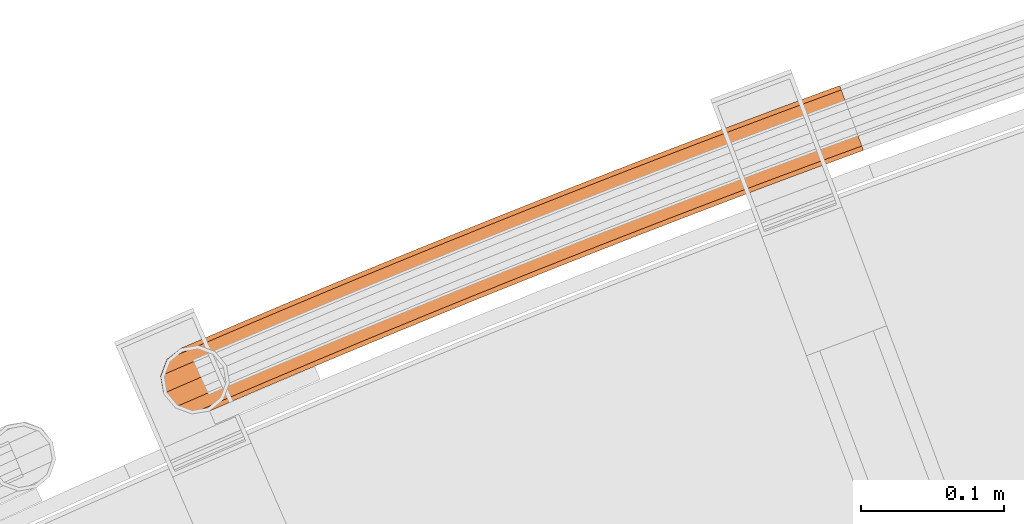
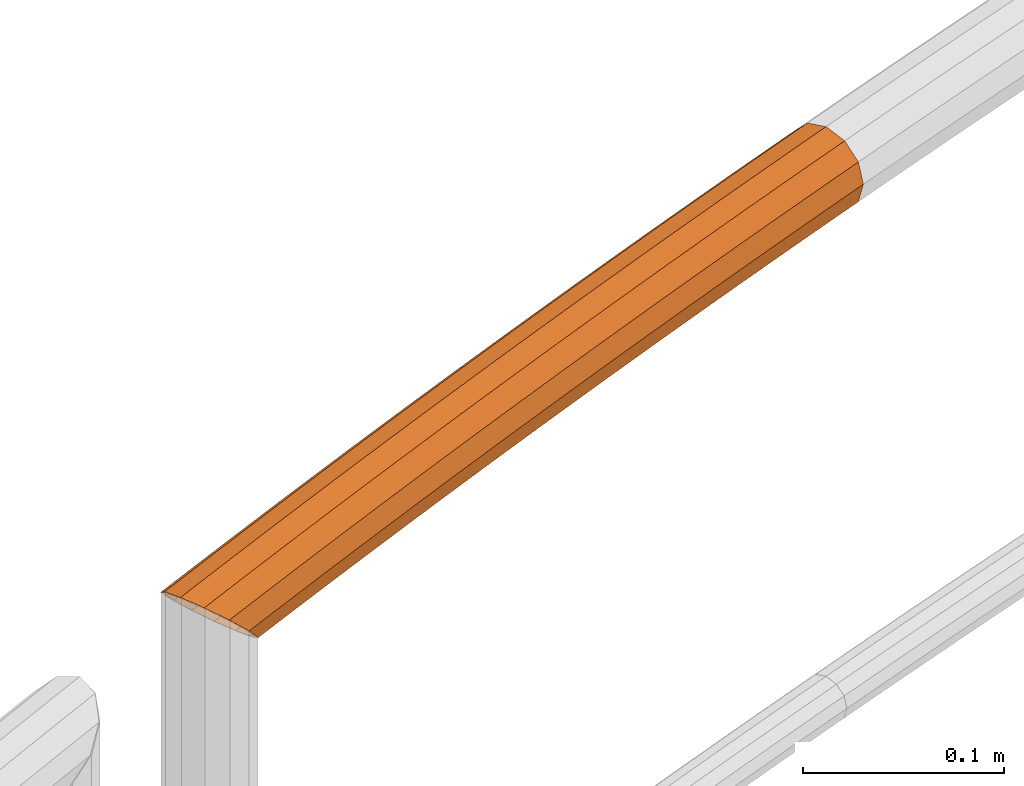
# One storey, part 99 of 126: 1 proxy.
"""IFC2X3 building model written with IfcOpenShell, lengths in millimetres."""

from ifc_helpers import new_model, si_unit, origin, origin_with_axes, place, context, project, spatial, faceted_brep, material, element, save


model = new_model("IFC2X3")

# Units and contexts
context_of_model_1 = context(None, 3, precision=0.1, world=origin())
context_of_model_2 = context(None, 3, precision=0.1, world=origin())
ifc_project = project(units=[si_unit("LENGTHUNIT", "METRE", prefix="MILLI"), si_unit("AREAUNIT", "SQUARE_METRE", prefix="CENTI"), si_unit("VOLUMEUNIT", "CUBIC_METRE", prefix="CENTI"), si_unit("MASSUNIT", "GRAM", prefix="KILO")], contexts=[context_of_model_1, context_of_model_2])

# Site, building, storey
site_placement = place(None, origin_with_axes())
site = spatial("IfcSite", under=ifc_project, at=site_placement, CompositionType="ELEMENT")
building_placement = place(site_placement, origin_with_axes())
building = spatial("IfcBuilding", under=site, at=building_placement, CompositionType="ELEMENT")
storey_placement = place(building_placement, origin_with_axes())
storey = spatial("IfcBuildingStorey", under=building, at=storey_placement, CompositionType="ELEMENT")

# Proxy
ifc_material = material(Name="S235JRG2")
proxy_placement = place(storey_placement, origin_with_axes())
element("IfcBuildingElementProxy", 1, at=proxy_placement, inside=storey, material=ifc_material, Name="HANDLAUF", context=context_of_model_2, shape_type="Brep", body=[
    faceted_brep([(4483.8006, 16126.451, 12181.915), (4479.0556, 16124.384, 12181.915), (4485.8133, 16121.809, 12176.855), (4478.9973, 16137.53, 12185.15), (4471.0342, 16134.061, 12185.15), (4474.194, 16148.608, 12181.915), (4468.9466, 16146.322, 12181.915), (4471.8648, 16153.98, 12176.059), (4474.6912, 16147.461, 12179.749), (4471.4552, 16146.052, 12179.749), (4473.2548, 16150.774, 12176.138), (4478.9973, 16137.53, 12182.65), (4473.3267, 16135.059, 12182.65), (4483.3034, 16127.598, 12179.749), (4480.5177, 16126.385, 12179.749), (4484.485, 16124.873, 12176.779), (4497.8774, 16171.979, 12161.0), (4499.1541, 16169.006, 12148.925), (4495.5368, 16167.445, 12148.925), (4483.0922, 16165.599, 12161.0), (4500.6685, 16165.479, 12145.087), (4515.6591, 16130.571, 12148.925), (4513.0476, 16129.444, 12148.925), (4514.507, 16133.254, 12146.005), (4516.9358, 16127.598, 12161.0), (4503.3118, 16121.719, 12161.0), (4515.6591, 16130.571, 12173.075), (4490.8671, 16119.873, 12173.075), (4512.1712, 16138.693, 12181.915), (4507.4066, 16149.788, 12185.15), (4502.642, 16160.884, 12181.915), (4473.3564, 16157.874, 12173.075), (4499.1541, 16169.006, 12173.075), (4498.8639, 16169.682, 12161.0), (4500.0084, 16167.016, 12171.825), (4475.4108, 16156.403, 12171.825), (4484.1387, 16163.328, 12161.0), (4503.1352, 16159.735, 12179.749), (4507.4066, 16149.788, 12182.65), (4511.678, 16139.842, 12179.749), (4514.8048, 16132.56, 12171.825), (4491.1088, 16122.335, 12171.825), (4515.9494, 16129.895, 12161.0), (4502.2652, 16123.99, 12161.0), (4514.8048, 16132.56, 12150.175), (4510.9931, 16130.915, 12150.175), (4513.1232, 16136.476, 12145.913), (4500.0084, 16167.016, 12150.175), (4495.2951, 16164.983, 12150.175), (4501.9816, 16162.421, 12145.174), (4526.4068, 16184.171, 12161.0), (4527.6731, 16181.194, 12148.925), (4531.1327, 16173.059, 12140.085), (4507.3634, 16162.901, 12140.085), (4535.8585, 16161.948, 12136.85), (4515.3951, 16153.202, 12136.85), (4540.5844, 16150.836, 12140.085), (4517.4741, 16140.959, 12140.085), (4544.0439, 16142.701, 12148.925), (4545.3102, 16139.724, 12161.0), (4544.0439, 16142.701, 12173.075), (4540.5844, 16150.836, 12181.915), (4535.8585, 16161.948, 12185.15), (4531.1327, 16173.059, 12181.915), (4527.6731, 16181.194, 12173.075), (4527.3853, 16181.871, 12161.0), (4528.5205, 16179.201, 12171.825), (4531.6219, 16171.909, 12179.749), (4535.8585, 16161.948, 12182.65), (4540.0952, 16151.986, 12179.749), (4543.1966, 16144.694, 12171.825), (4544.3318, 16142.025, 12161.0), (4543.1966, 16144.694, 12150.175), (4514.9591, 16141.244, 12142.251), (4540.0952, 16151.986, 12142.251), (4535.8585, 16161.948, 12139.35), (4513.0953, 16152.219, 12139.35), (4531.6219, 16171.909, 12142.251), (4505.8951, 16160.914, 12142.251), (4528.5205, 16179.201, 12150.175), (4554.9787, 16196.264, 12161.0), (4556.2346, 16193.282, 12148.925), (4559.6657, 16185.136, 12140.085), (4564.3527, 16174.007, 12136.85), (4569.0398, 16162.879, 12140.085), (4572.4709, 16154.733, 12148.925), (4573.7268, 16151.751, 12161.0), (4572.4709, 16154.733, 12173.075), (4569.0398, 16162.879, 12181.915), (4564.3527, 16174.007, 12185.15), (4559.6657, 16185.136, 12181.915), (4556.2346, 16193.282, 12173.075), (4555.9491, 16193.96, 12161.0), (4557.0749, 16191.287, 12171.825), (4560.1509, 16183.984, 12179.749), (4564.3527, 16174.007, 12182.65), (4568.5546, 16164.031, 12179.749), (4571.6305, 16156.728, 12171.825), (4572.7564, 16154.055, 12161.0), (4571.6305, 16156.728, 12150.175), (4568.5546, 16164.031, 12142.251), (4564.3527, 16174.007, 12139.35), (4560.1509, 16183.984, 12142.251), (4557.0749, 16191.287, 12150.175), (4583.5925, 16208.257, 12161.0), (4584.838, 16205.271, 12148.925), (4588.2407, 16197.112, 12140.085), (4592.8888, 16185.968, 12136.85), (4597.537, 16174.823, 12140.085), (4600.9397, 16166.665, 12148.925), (4602.1852, 16163.679, 12161.0), (4600.9397, 16166.665, 12173.075), (4597.537, 16174.823, 12181.915), (4592.8888, 16185.968, 12185.15), (4588.2407, 16197.112, 12181.915), (4584.838, 16205.271, 12173.075), (4584.5549, 16205.949, 12161.0), (4585.6714, 16203.272, 12171.825), (4588.7219, 16195.959, 12179.749), (4592.8888, 16185.968, 12182.65), (4597.0558, 16175.977, 12179.749), (4600.1063, 16168.663, 12171.825), (4601.2228, 16165.986, 12161.0), (4600.1063, 16168.663, 12150.175), (4597.0558, 16175.977, 12142.251), (4592.8888, 16185.968, 12139.35), (4588.7219, 16195.959, 12142.251), (4585.6714, 16203.272, 12150.175), (4612.2481, 16220.15, 12161.0), (4613.4831, 16217.159, 12148.925), (4616.8573, 16208.989, 12140.085), (4621.4665, 16197.828, 12136.85), (4626.0758, 16186.668, 12140.085), (4629.45, 16178.497, 12148.925), (4630.685, 16175.507, 12161.0), (4629.45, 16178.497, 12173.075), (4626.0758, 16186.668, 12181.915), (4621.4665, 16197.828, 12185.15), (4616.8573, 16208.989, 12181.915), (4613.4831, 16217.159, 12173.075), (4613.2024, 16217.839, 12161.0), (4614.3096, 16215.158, 12171.825), (4617.3345, 16207.834, 12179.749), (4621.4665, 16197.828, 12182.65), (4625.5986, 16187.823, 12179.749), (4628.6235, 16180.499, 12171.825), (4629.7307, 16177.818, 12161.0), (4628.6235, 16180.499, 12150.175), (4625.5986, 16187.823, 12142.251), (4621.4665, 16197.828, 12139.35), (4617.3345, 16207.834, 12142.251), (4614.3096, 16215.158, 12150.175), (4640.945, 16231.943, 12161.0), (4642.1696, 16228.948, 12148.925), (4645.5152, 16220.766, 12140.085), (4650.0855, 16209.589, 12136.85), (4654.6557, 16198.413, 12140.085), (4658.0013, 16190.231, 12148.925), (4659.2259, 16187.236, 12161.0), (4658.0013, 16190.231, 12173.075), (4654.6557, 16198.413, 12181.915), (4650.0855, 16209.589, 12185.15), (4645.5152, 16220.766, 12181.915), (4642.1696, 16228.948, 12173.075), (4641.8912, 16229.629, 12161.0), (4642.989, 16226.944, 12171.825), (4645.9883, 16219.609, 12179.749), (4650.0855, 16209.589, 12182.65), (4654.1826, 16199.57, 12179.749), (4657.1819, 16192.235, 12171.825), (4658.2797, 16189.55, 12161.0), (4657.1819, 16192.235, 12150.175), (4654.1826, 16199.57, 12142.251), (4650.0855, 16209.589, 12139.35), (4645.9883, 16219.609, 12142.251), (4642.989, 16226.944, 12150.175), (4669.6829, 16243.635, 12161.0), (4670.897, 16240.636, 12148.925), (4674.2141, 16232.443, 12140.085), (4678.7453, 16221.25, 12136.85), (4683.2765, 16210.057, 12140.085), (4686.5935, 16201.864, 12148.925), (4687.8077, 16198.865, 12161.0), (4686.5935, 16201.864, 12173.075), (4683.2765, 16210.057, 12181.915), (4678.7453, 16221.25, 12185.15), (4674.2141, 16232.443, 12181.915), (4670.897, 16240.636, 12173.075), (4670.621, 16241.318, 12161.0), (4671.7095, 16238.629, 12171.825), (4674.6831, 16231.284, 12179.749), (4678.7453, 16221.25, 12182.65), (4682.8074, 16211.216, 12179.749), (4685.7811, 16203.871, 12171.825), (4686.8695, 16201.182, 12161.0), (4685.7811, 16203.871, 12150.175), (4682.8074, 16211.216, 12142.251), (4678.7453, 16221.25, 12139.35), (4674.6831, 16231.284, 12142.251), (4671.7095, 16238.629, 12150.175), (4698.4614, 16255.228, 12161.0), (4699.665, 16252.224, 12148.925), (4702.9535, 16244.019, 12140.085), (4707.4456, 16232.811, 12136.85), (4711.9377, 16221.602, 12140.085), (4715.2261, 16213.397, 12148.925), (4716.4298, 16210.394, 12161.0), (4715.2261, 16213.397, 12173.075), (4711.9377, 16221.602, 12181.915), (4707.4456, 16232.811, 12185.15), (4702.9535, 16244.019, 12181.915), (4699.665, 16252.224, 12173.075), (4699.3914, 16252.907, 12161.0), (4700.4705, 16250.215, 12171.825), (4703.4185, 16242.859, 12179.749), (4707.4456, 16232.811, 12182.65), (4711.4727, 16222.763, 12179.749), (4714.4207, 16215.407, 12171.825), (4715.4998, 16212.715, 12161.0), (4714.4207, 16215.407, 12150.175), (4711.4727, 16222.763, 12142.251), (4707.4456, 16232.811, 12139.35), (4703.4185, 16242.859, 12142.251), (4700.4705, 16250.215, 12150.175), (4727.2802, 16266.719, 12161.0), (4728.4734, 16263.712, 12148.925), (4731.7332, 16255.495, 12140.085), (4736.1861, 16244.271, 12136.85), (4740.6391, 16233.047, 12140.085), (4743.8988, 16224.831, 12148.925), (4745.092, 16221.823, 12161.0), (4743.8988, 16224.831, 12173.075), (4740.6391, 16233.047, 12181.915), (4736.1861, 16244.271, 12185.15), (4731.7332, 16255.495, 12181.915), (4728.4734, 16263.712, 12173.075), (4728.2021, 16264.395, 12161.0), (4729.2718, 16261.699, 12171.825), (4732.1941, 16254.333, 12179.749), (4736.1861, 16244.271, 12182.65), (4740.1781, 16234.209, 12179.749), (4743.1004, 16226.843, 12171.825), (4744.1701, 16224.147, 12161.0), (4743.1004, 16226.843, 12150.175), (4740.1781, 16234.209, 12142.251), (4736.1861, 16244.271, 12139.35), (4732.1941, 16254.333, 12142.251), (4729.2718, 16261.699, 12150.175), (4756.139, 16278.11, 12161.0), (4757.3216, 16275.099, 12148.925), (4760.5527, 16266.871, 12140.085), (4764.9664, 16255.631, 12136.85), (4769.3802, 16244.392, 12140.085), (4772.6113, 16236.164, 12148.925), (4773.7939, 16233.153, 12161.0), (4772.6113, 16236.164, 12173.075), (4769.3802, 16244.392, 12181.915), (4764.9664, 16255.631, 12185.15), (4760.5527, 16266.871, 12181.915), (4757.3216, 16275.099, 12173.075), (4757.0528, 16275.783, 12161.0), (4758.113, 16273.083, 12171.825), (4761.0096, 16265.707, 12179.749), (4764.9664, 16255.631, 12182.65), (4768.9233, 16245.555, 12179.749), (4771.8199, 16238.179, 12171.825), (4772.8801, 16235.479, 12161.0), (4771.8199, 16238.179, 12150.175), (4768.9233, 16245.555, 12142.251), (4764.9664, 16255.631, 12139.35), (4761.0096, 16265.707, 12142.251), (4758.113, 16273.083, 12150.175), (4785.0373, 16289.401, 12161.0), (4786.2094, 16286.385, 12148.925), (4789.4118, 16278.146, 12140.085), (4793.7863, 16266.891, 12136.85), (4798.1607, 16255.636, 12140.085), (4801.3631, 16247.397, 12148.925), (4802.5352, 16244.381, 12161.0), (4801.3631, 16247.397, 12173.075), (4798.1607, 16255.636, 12181.915), (4793.7863, 16266.891, 12185.15), (4789.4118, 16278.146, 12181.915), (4786.2094, 16286.385, 12173.075), (4785.943, 16287.07, 12161.0), (4786.9938, 16284.367, 12171.825), (4789.8646, 16276.981, 12179.749), (4793.7863, 16266.891, 12182.65), (4797.7079, 16256.801, 12179.749), (4800.5787, 16249.415, 12171.825), (4801.6295, 16246.712, 12161.0), (4800.5787, 16249.415, 12150.175), (4797.7079, 16256.801, 12142.251), (4793.7863, 16266.891, 12139.35), (4789.8646, 16276.981, 12142.251), (4786.9938, 16284.367, 12150.175), (4813.9749, 16300.59, 12161.0), (4815.1365, 16297.57, 12148.925), (4818.31, 16289.32, 12140.085), (4822.6452, 16278.05, 12136.85), (4826.9804, 16266.78, 12140.085), (4830.1539, 16258.53, 12148.925), (4831.3155, 16255.51, 12161.0), (4830.1539, 16258.53, 12173.075), (4826.9804, 16266.78, 12181.915), (4822.6452, 16278.05, 12185.15), (4818.31, 16289.32, 12181.915), (4815.1365, 16297.57, 12173.075), (4814.8724, 16298.256, 12161.0), (4815.9138, 16295.549, 12171.825), (4818.7588, 16288.153, 12179.749), (4822.6452, 16278.05, 12182.65), (4826.5316, 16267.947, 12179.749), (4829.3766, 16260.55, 12171.825), (4830.418, 16257.843, 12161.0), (4829.3766, 16260.55, 12150.175), (4826.5316, 16267.947, 12142.251), (4822.6452, 16278.05, 12139.35), (4818.7588, 16288.153, 12142.251), (4815.9138, 16295.549, 12150.175), (4842.9513, 16311.678, 12161.0), (4844.1024, 16308.654, 12148.925), (4847.2471, 16300.393, 12140.085), (4851.5429, 16289.108, 12136.85), (4855.8387, 16277.823, 12140.085), (4858.9835, 16269.562, 12148.925), (4860.1345, 16266.538, 12161.0), (4858.9835, 16269.562, 12173.075), (4855.8387, 16277.823, 12181.915), (4851.5429, 16289.108, 12185.15), (4847.2471, 16300.393, 12181.915), (4844.1024, 16308.654, 12173.075), (4843.8407, 16309.342, 12161.0), (4844.8726, 16306.631, 12171.825), (4847.6918, 16299.225, 12179.749), (4851.5429, 16289.108, 12182.65), (4855.394, 16278.991, 12179.749), (4858.2132, 16271.585, 12171.825), (4859.2451, 16268.874, 12161.0), (4858.2132, 16271.585, 12150.175), (4855.394, 16278.991, 12142.251), (4851.5429, 16289.108, 12139.35), (4847.6918, 16299.225, 12142.251), (4844.8726, 16306.631, 12150.175), (4871.9663, 16322.665, 12161.0), (4873.1068, 16319.637, 12148.925), (4876.2227, 16311.365, 12140.085), (4880.4791, 16300.065, 12136.85), (4884.7355, 16288.765, 12140.085), (4887.8513, 16280.493, 12148.925), (4888.9918, 16277.465, 12161.0), (4887.8513, 16280.493, 12173.075), (4884.7355, 16288.765, 12181.915), (4880.4791, 16300.065, 12185.15), (4876.2227, 16311.365, 12181.915), (4873.1068, 16319.637, 12173.075), (4872.8475, 16320.326, 12161.0), (4873.87, 16317.611, 12171.825), (4876.6633, 16310.195, 12179.749), (4880.4791, 16300.065, 12182.65), (4884.2948, 16289.935, 12179.749), (4887.0882, 16282.519, 12171.825), (4888.1106, 16279.805, 12161.0), (4887.0882, 16282.519, 12150.175), (4884.2948, 16289.935, 12142.251), (4880.4791, 16300.065, 12139.35), (4876.6633, 16310.195, 12142.251), (4873.87, 16317.611, 12150.175), (4901.0195, 16333.551, 12161.0), (4902.1494, 16330.519, 12148.925), (4905.2364, 16322.236, 12140.085), (4909.4533, 16310.921, 12136.85), (4913.6702, 16299.606, 12140.085), (4916.7572, 16291.323, 12148.925), (4917.8871, 16288.292, 12161.0), (4916.7572, 16291.323, 12173.075), (4913.6702, 16299.606, 12181.915), (4909.4533, 16310.921, 12185.15), (4905.2364, 16322.236, 12181.915), (4902.1494, 16330.519, 12173.075), (4901.8925, 16331.208, 12161.0), (4902.9055, 16328.49, 12171.825), (4905.6729, 16321.065, 12179.749), (4909.4533, 16310.921, 12182.65), (4913.2337, 16300.778, 12179.749), (4916.0011, 16293.352, 12171.825), (4917.014, 16290.634, 12161.0), (4916.0011, 16293.352, 12150.175), (4913.2337, 16300.778, 12142.251), (4909.4533, 16310.921, 12139.35), (4905.6729, 16321.065, 12142.251), (4902.9055, 16328.49, 12150.175), (4930.1104, 16344.335, 12161.0), (4931.2298, 16341.299, 12148.925), (4934.2878, 16333.005, 12140.085), (4938.4652, 16321.676, 12136.85), (4942.6426, 16310.347, 12140.085), (4945.7007, 16302.053, 12148.925), (4946.82, 16299.017, 12161.0), (4945.7007, 16302.053, 12173.075), (4942.6426, 16310.347, 12181.915), (4938.4652, 16321.676, 12185.15), (4934.2878, 16333.005, 12181.915), (4931.2298, 16341.299, 12173.075), (4930.9753, 16341.989, 12161.0), (4931.9788, 16339.268, 12171.825), (4934.7203, 16331.833, 12179.749), (4938.4652, 16321.676, 12182.65), (4942.2102, 16311.519, 12179.749), (4944.9517, 16304.084, 12171.825), (4945.9551, 16301.363, 12161.0), (4944.9517, 16304.084, 12150.175), (4942.2102, 16311.519, 12142.251), (4938.4652, 16321.676, 12139.35), (4934.7203, 16331.833, 12142.251), (4931.9788, 16339.268, 12150.175), (4944.6728, 16349.675, 12161.0), (4945.7869, 16346.638, 12148.925), (4948.8307, 16338.339, 12140.085), (4952.9886, 16327.002, 12136.85), (4957.1465, 16315.666, 12140.085), (4960.1904, 16307.367, 12148.925), (4961.3045, 16304.329, 12161.0), (4960.1904, 16307.367, 12173.075), (4957.1465, 16315.666, 12181.915), (4952.9886, 16327.002, 12185.15), (4948.8307, 16338.339, 12181.915), (4945.7869, 16346.638, 12173.075), (4945.5336, 16347.328, 12161.0), (4946.5324, 16344.605, 12171.825), (4949.2611, 16337.165, 12179.749), (4952.9886, 16327.002, 12182.65), (4956.7161, 16316.839, 12179.749), (4959.4448, 16309.4, 12171.825), (4960.4436, 16306.676, 12161.0), (4959.4448, 16309.4, 12150.175), (4956.7161, 16316.839, 12142.251), (4952.9886, 16327.002, 12139.35), (4949.2611, 16337.165, 12142.251), (4946.5324, 16344.605, 12150.175)], [[[0, 1, 2]], [[0, 3, 4, 1]], [[3, 5, 6, 4]], [[5, 7, 6]], [[8, 9, 10]], [[8, 11, 12, 9]], [[11, 13, 14, 12]], [[13, 15, 14]], [[16, 17, 18, 19]], [[17, 20, 18]], [[21, 22, 23]], [[21, 24, 25, 22]], [[24, 26, 27, 25]], [[0, 2, 27, 26, 28]], [[0, 28, 29, 3]], [[3, 29, 30, 5]], [[31, 7, 5, 30, 32]], [[16, 19, 31, 32]], [[33, 34, 35, 36]], [[35, 34, 37, 8, 10]], [[8, 37, 38, 11]], [[11, 38, 39, 13]], [[13, 39, 40, 41, 15]], [[40, 42, 43, 41]], [[42, 44, 45, 43]], [[44, 46, 45]], [[47, 48, 49]], [[33, 36, 48, 47]], [[16, 50, 51, 17]], [[17, 51, 52, 53, 20]], [[52, 54, 55, 53]], [[54, 56, 57, 55]], [[57, 56, 58, 21, 23]], [[21, 58, 59, 24]], [[24, 59, 60, 26]], [[26, 60, 61, 28]], [[28, 61, 62, 29]], [[29, 62, 63, 30]], [[30, 63, 64, 32]], [[32, 64, 50, 16]], [[33, 65, 66, 34]], [[34, 66, 67, 37]], [[37, 67, 68, 38]], [[38, 68, 69, 39]], [[39, 69, 70, 40]], [[40, 70, 71, 42]], [[42, 71, 72, 44]], [[73, 46, 44, 72, 74]], [[74, 75, 76, 73]], [[75, 77, 78, 76]], [[47, 49, 78, 77, 79]], [[47, 79, 65, 33]], [[50, 80, 81, 51]], [[51, 81, 82, 52]], [[52, 82, 83, 54]], [[54, 83, 84, 56]], [[56, 84, 85, 58]], [[58, 85, 86, 59]], [[59, 86, 87, 60]], [[60, 87, 88, 61]], [[61, 88, 89, 62]], [[62, 89, 90, 63]], [[63, 90, 91, 64]], [[64, 91, 80, 50]], [[65, 92, 93, 66]], [[66, 93, 94, 67]], [[67, 94, 95, 68]], [[68, 95, 96, 69]], [[69, 96, 97, 70]], [[70, 97, 98, 71]], [[71, 98, 99, 72]], [[72, 99, 100, 74]], [[74, 100, 101, 75]], [[75, 101, 102, 77]], [[77, 102, 103, 79]], [[79, 103, 92, 65]], [[80, 104, 105, 81]], [[81, 105, 106, 82]], [[82, 106, 107, 83]], [[83, 107, 108, 84]], [[84, 108, 109, 85]], [[85, 109, 110, 86]], [[86, 110, 111, 87]], [[87, 111, 112, 88]], [[88, 112, 113, 89]], [[89, 113, 114, 90]], [[90, 114, 115, 91]], [[91, 115, 104, 80]], [[92, 116, 117, 93]], [[93, 117, 118, 94]], [[94, 118, 119, 95]], [[95, 119, 120, 96]], [[96, 120, 121, 97]], [[97, 121, 122, 98]], [[98, 122, 123, 99]], [[99, 123, 124, 100]], [[100, 124, 125, 101]], [[101, 125, 126, 102]], [[102, 126, 127, 103]], [[103, 127, 116, 92]], [[104, 128, 129, 105]], [[105, 129, 130, 106]], [[106, 130, 131, 107]], [[107, 131, 132, 108]], [[108, 132, 133, 109]], [[109, 133, 134, 110]], [[110, 134, 135, 111]], [[111, 135, 136, 112]], [[112, 136, 137, 113]], [[113, 137, 138, 114]], [[114, 138, 139, 115]], [[115, 139, 128, 104]], [[116, 140, 141, 117]], [[117, 141, 142, 118]], [[118, 142, 143, 119]], [[119, 143, 144, 120]], [[120, 144, 145, 121]], [[121, 145, 146, 122]], [[122, 146, 147, 123]], [[123, 147, 148, 124]], [[124, 148, 149, 125]], [[125, 149, 150, 126]], [[126, 150, 151, 127]], [[127, 151, 140, 116]], [[128, 152, 153, 129]], [[129, 153, 154, 130]], [[130, 154, 155, 131]], [[131, 155, 156, 132]], [[132, 156, 157, 133]], [[133, 157, 158, 134]], [[134, 158, 159, 135]], [[135, 159, 160, 136]], [[136, 160, 161, 137]], [[137, 161, 162, 138]], [[138, 162, 163, 139]], [[139, 163, 152, 128]], [[140, 164, 165, 141]], [[141, 165, 166, 142]], [[142, 166, 167, 143]], [[143, 167, 168, 144]], [[144, 168, 169, 145]], [[145, 169, 170, 146]], [[146, 170, 171, 147]], [[147, 171, 172, 148]], [[148, 172, 173, 149]], [[149, 173, 174, 150]], [[150, 174, 175, 151]], [[151, 175, 164, 140]], [[152, 176, 177, 153]], [[153, 177, 178, 154]], [[154, 178, 179, 155]], [[155, 179, 180, 156]], [[156, 180, 181, 157]], [[157, 181, 182, 158]], [[158, 182, 183, 159]], [[159, 183, 184, 160]], [[160, 184, 185, 161]], [[161, 185, 186, 162]], [[162, 186, 187, 163]], [[163, 187, 176, 152]], [[164, 188, 189, 165]], [[165, 189, 190, 166]], [[166, 190, 191, 167]], [[167, 191, 192, 168]], [[168, 192, 193, 169]], [[169, 193, 194, 170]], [[170, 194, 195, 171]], [[171, 195, 196, 172]], [[172, 196, 197, 173]], [[173, 197, 198, 174]], [[174, 198, 199, 175]], [[175, 199, 188, 164]], [[176, 200, 201, 177]], [[177, 201, 202, 178]], [[178, 202, 203, 179]], [[179, 203, 204, 180]], [[180, 204, 205, 181]], [[181, 205, 206, 182]], [[182, 206, 207, 183]], [[183, 207, 208, 184]], [[184, 208, 209, 185]], [[185, 209, 210, 186]], [[186, 210, 211, 187]], [[187, 211, 200, 176]], [[188, 212, 213, 189]], [[189, 213, 214, 190]], [[190, 214, 215, 191]], [[191, 215, 216, 192]], [[192, 216, 217, 193]], [[193, 217, 218, 194]], [[194, 218, 219, 195]], [[195, 219, 220, 196]], [[196, 220, 221, 197]], [[197, 221, 222, 198]], [[198, 222, 223, 199]], [[199, 223, 212, 188]], [[200, 224, 225, 201]], [[201, 225, 226, 202]], [[202, 226, 227, 203]], [[203, 227, 228, 204]], [[204, 228, 229, 205]], [[205, 229, 230, 206]], [[206, 230, 231, 207]], [[207, 231, 232, 208]], [[208, 232, 233, 209]], [[209, 233, 234, 210]], [[210, 234, 235, 211]], [[211, 235, 224, 200]], [[212, 236, 237, 213]], [[213, 237, 238, 214]], [[214, 238, 239, 215]], [[215, 239, 240, 216]], [[216, 240, 241, 217]], [[217, 241, 242, 218]], [[218, 242, 243, 219]], [[219, 243, 244, 220]], [[220, 244, 245, 221]], [[221, 245, 246, 222]], [[222, 246, 247, 223]], [[223, 247, 236, 212]], [[224, 248, 249, 225]], [[225, 249, 250, 226]], [[226, 250, 251, 227]], [[227, 251, 252, 228]], [[228, 252, 253, 229]], [[229, 253, 254, 230]], [[230, 254, 255, 231]], [[231, 255, 256, 232]], [[232, 256, 257, 233]], [[233, 257, 258, 234]], [[234, 258, 259, 235]], [[235, 259, 248, 224]], [[236, 260, 261, 237]], [[237, 261, 262, 238]], [[238, 262, 263, 239]], [[239, 263, 264, 240]], [[240, 264, 265, 241]], [[241, 265, 266, 242]], [[242, 266, 267, 243]], [[243, 267, 268, 244]], [[244, 268, 269, 245]], [[245, 269, 270, 246]], [[246, 270, 271, 247]], [[247, 271, 260, 236]], [[248, 272, 273, 249]], [[249, 273, 274, 250]], [[250, 274, 275, 251]], [[251, 275, 276, 252]], [[252, 276, 277, 253]], [[253, 277, 278, 254]], [[254, 278, 279, 255]], [[255, 279, 280, 256]], [[256, 280, 281, 257]], [[257, 281, 282, 258]], [[258, 282, 283, 259]], [[259, 283, 272, 248]], [[260, 284, 285, 261]], [[261, 285, 286, 262]], [[262, 286, 287, 263]], [[263, 287, 288, 264]], [[264, 288, 289, 265]], [[265, 289, 290, 266]], [[266, 290, 291, 267]], [[267, 291, 292, 268]], [[268, 292, 293, 269]], [[269, 293, 294, 270]], [[270, 294, 295, 271]], [[271, 295, 284, 260]], [[272, 296, 297, 273]], [[273, 297, 298, 274]], [[274, 298, 299, 275]], [[275, 299, 300, 276]], [[276, 300, 301, 277]], [[277, 301, 302, 278]], [[278, 302, 303, 279]], [[279, 303, 304, 280]], [[280, 304, 305, 281]], [[281, 305, 306, 282]], [[282, 306, 307, 283]], [[283, 307, 296, 272]], [[284, 308, 309, 285]], [[285, 309, 310, 286]], [[286, 310, 311, 287]], [[287, 311, 312, 288]], [[288, 312, 313, 289]], [[289, 313, 314, 290]], [[290, 314, 315, 291]], [[291, 315, 316, 292]], [[292, 316, 317, 293]], [[293, 317, 318, 294]], [[294, 318, 319, 295]], [[295, 319, 308, 284]], [[296, 320, 321, 297]], [[297, 321, 322, 298]], [[298, 322, 323, 299]], [[299, 323, 324, 300]], [[300, 324, 325, 301]], [[301, 325, 326, 302]], [[302, 326, 327, 303]], [[303, 327, 328, 304]], [[304, 328, 329, 305]], [[305, 329, 330, 306]], [[306, 330, 331, 307]], [[307, 331, 320, 296]], [[308, 332, 333, 309]], [[309, 333, 334, 310]], [[310, 334, 335, 311]], [[311, 335, 336, 312]], [[312, 336, 337, 313]], [[313, 337, 338, 314]], [[314, 338, 339, 315]], [[315, 339, 340, 316]], [[316, 340, 341, 317]], [[317, 341, 342, 318]], [[318, 342, 343, 319]], [[319, 343, 332, 308]], [[320, 344, 345, 321]], [[321, 345, 346, 322]], [[322, 346, 347, 323]], [[323, 347, 348, 324]], [[324, 348, 349, 325]], [[325, 349, 350, 326]], [[326, 350, 351, 327]], [[327, 351, 352, 328]], [[328, 352, 353, 329]], [[329, 353, 354, 330]], [[330, 354, 355, 331]], [[331, 355, 344, 320]], [[332, 356, 357, 333]], [[333, 357, 358, 334]], [[334, 358, 359, 335]], [[335, 359, 360, 336]], [[336, 360, 361, 337]], [[337, 361, 362, 338]], [[338, 362, 363, 339]], [[339, 363, 364, 340]], [[340, 364, 365, 341]], [[341, 365, 366, 342]], [[342, 366, 367, 343]], [[343, 367, 356, 332]], [[344, 368, 369, 345]], [[345, 369, 370, 346]], [[346, 370, 371, 347]], [[347, 371, 372, 348]], [[348, 372, 373, 349]], [[349, 373, 374, 350]], [[350, 374, 375, 351]], [[351, 375, 376, 352]], [[352, 376, 377, 353]], [[353, 377, 378, 354]], [[354, 378, 379, 355]], [[355, 379, 368, 344]], [[356, 380, 381, 357]], [[357, 381, 382, 358]], [[358, 382, 383, 359]], [[359, 383, 384, 360]], [[360, 384, 385, 361]], [[361, 385, 386, 362]], [[362, 386, 387, 363]], [[363, 387, 388, 364]], [[364, 388, 389, 365]], [[365, 389, 390, 366]], [[366, 390, 391, 367]], [[367, 391, 380, 356]], [[368, 392, 393, 369]], [[369, 393, 394, 370]], [[370, 394, 395, 371]], [[371, 395, 396, 372]], [[372, 396, 397, 373]], [[373, 397, 398, 374]], [[374, 398, 399, 375]], [[375, 399, 400, 376]], [[376, 400, 401, 377]], [[377, 401, 402, 378]], [[378, 402, 403, 379]], [[379, 403, 392, 368]], [[380, 404, 405, 381]], [[381, 405, 406, 382]], [[382, 406, 407, 383]], [[383, 407, 408, 384]], [[384, 408, 409, 385]], [[385, 409, 410, 386]], [[386, 410, 411, 387]], [[387, 411, 412, 388]], [[388, 412, 413, 389]], [[389, 413, 414, 390]], [[390, 414, 415, 391]], [[391, 415, 404, 380]], [[392, 416, 417, 393]], [[393, 417, 418, 394]], [[394, 418, 419, 395]], [[395, 419, 420, 396]], [[396, 420, 421, 397]], [[397, 421, 422, 398]], [[398, 422, 423, 399]], [[399, 423, 424, 400]], [[400, 424, 425, 401]], [[401, 425, 426, 402]], [[402, 426, 427, 403]], [[392, 403, 427, 416]], [[404, 428, 429, 405]], [[405, 429, 430, 406]], [[406, 430, 431, 407]], [[407, 431, 432, 408]], [[408, 432, 433, 409]], [[409, 433, 434, 410]], [[410, 434, 435, 411]], [[411, 435, 436, 412]], [[412, 436, 437, 413]], [[413, 437, 438, 414]], [[414, 438, 439, 415]], [[404, 415, 439, 428]], [[19, 18, 20, 53, 55, 57, 23, 22, 25, 27, 2, 1, 4, 6, 7, 31], [9, 12, 14, 15, 41, 43, 45, 46, 73, 76, 78, 49, 48, 36, 35, 10]], [[422, 421, 420, 419, 418, 417, 416, 427, 426, 425, 424, 423], [428, 439, 438, 437, 436, 435, 434, 433, 432, 431, 430, 429]]]),
])

save(model, "model.ifc")
